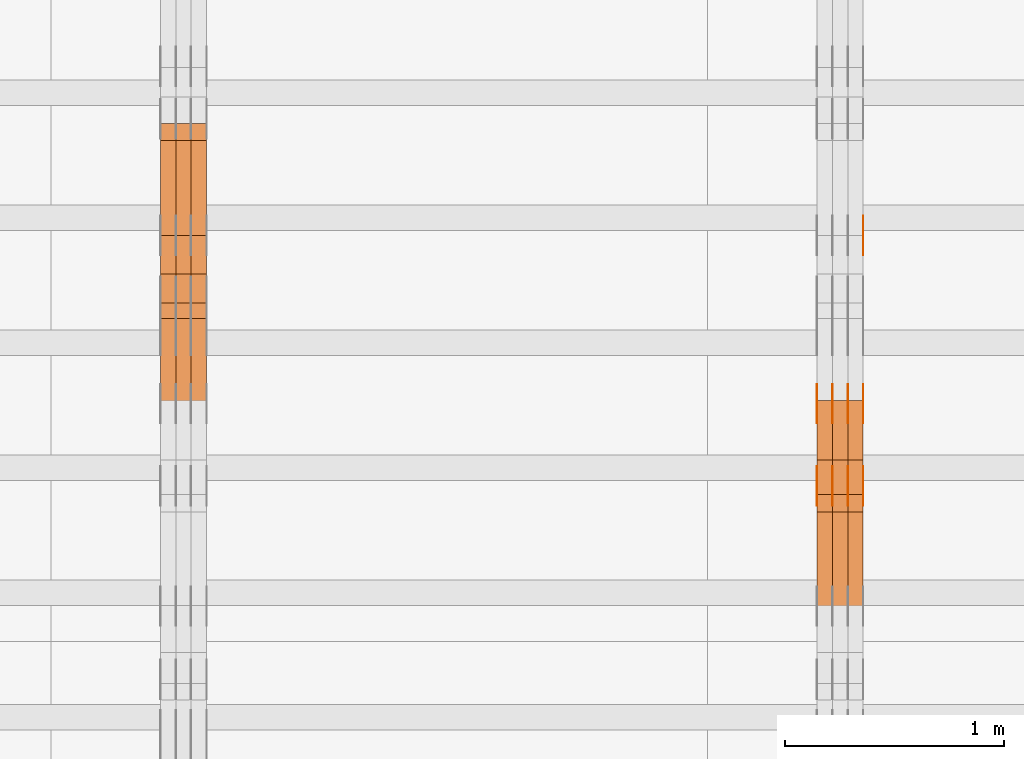
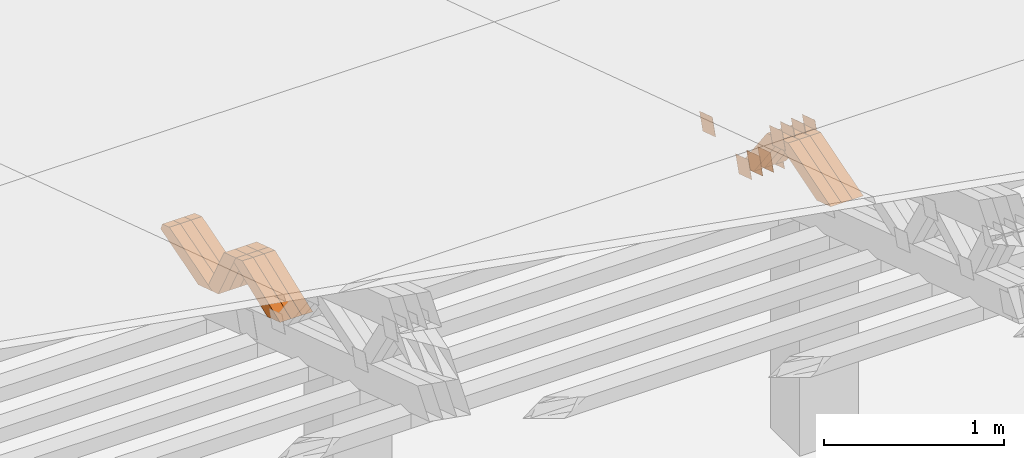
# One storey, part 340 of 385: 28 proxies.
"""IFC2X3 building model written with IfcOpenShell, lengths in millimetres."""

from ifc_helpers import new_model, entity, si_unit, converted_unit, derived_unit, direction, frame, origin, place, context, subcontext, project, spatial, polyline, outline, extrude, source, transform, mapped, material, type_object, type_shapes, element, save


model = new_model("IFC2X3")

# Units and contexts
model_context = context("Model", 3, precision=0.01, world=origin(), true_north=direction((6.12303176911189e-17, 1.0)))
body_context = subcontext(model_context, "Body", "Model", "MODEL_VIEW")
ifc_project = project(units=[si_unit("LENGTHUNIT", "METRE", prefix="MILLI"), si_unit("AREAUNIT", "SQUARE_METRE"), si_unit("VOLUMEUNIT", "CUBIC_METRE"), converted_unit("PLANEANGLEUNIT", "DEGREE", entity("IfcRatioMeasure", 0.0174532925199433), si_unit("PLANEANGLEUNIT", "RADIAN"), dimensions=[0, 0, 0, 0, 0, 0, 0]), si_unit("MASSUNIT", "GRAM", prefix="KILO"), derived_unit("MASSDENSITYUNIT", [(si_unit("MASSUNIT", "GRAM", prefix="KILO"), 1), (si_unit("LENGTHUNIT", "METRE"), -3)]), si_unit("TIMEUNIT", "SECOND"), si_unit("FREQUENCYUNIT", "HERTZ"), si_unit("THERMODYNAMICTEMPERATUREUNIT", "DEGREE_CELSIUS"), derived_unit("THERMALTRANSMITTANCEUNIT", [(si_unit("MASSUNIT", "GRAM", prefix="KILO"), 1), (si_unit("THERMODYNAMICTEMPERATUREUNIT", "KELVIN"), -1), (si_unit("TIMEUNIT", "SECOND"), -3)]), derived_unit("VOLUMETRICFLOWRATEUNIT", [(si_unit("LENGTHUNIT", "METRE"), 3), (si_unit("TIMEUNIT", "SECOND"), -1)]), si_unit("ELECTRICCURRENTUNIT", "AMPERE"), si_unit("ELECTRICVOLTAGEUNIT", "VOLT"), si_unit("POWERUNIT", "WATT"), si_unit("FORCEUNIT", "NEWTON", prefix="KILO"), si_unit("ILLUMINANCEUNIT", "LUX"), si_unit("LUMINOUSFLUXUNIT", "LUMEN"), si_unit("LUMINOUSINTENSITYUNIT", "CANDELA"), derived_unit("USERDEFINED", [(si_unit("MASSUNIT", "GRAM", prefix="KILO"), -1), (si_unit("LENGTHUNIT", "METRE"), -2), (si_unit("TIMEUNIT", "SECOND"), 3), (si_unit("LUMINOUSFLUXUNIT", "LUMEN"), 1)]), derived_unit("LINEARVELOCITYUNIT", [(si_unit("LENGTHUNIT", "METRE"), 1), (si_unit("TIMEUNIT", "SECOND"), -1)]), si_unit("PRESSUREUNIT", "PASCAL"), derived_unit("USERDEFINED", [(si_unit("LENGTHUNIT", "METRE"), -2), (si_unit("MASSUNIT", "GRAM", prefix="KILO"), 1), (si_unit("TIMEUNIT", "SECOND"), -2)])], contexts=[model_context])

# Site, building, storey
site_placement = place(None, origin())
site = spatial("IfcSite", under=ifc_project, at=site_placement, CompositionType="ELEMENT")
building_placement = place(site_placement, origin())
building = spatial("IfcBuilding", under=site, at=building_placement, CompositionType="ELEMENT")
storey_placement = place(building_placement, origin())
storey = spatial("IfcBuildingStorey", under=building, at=storey_placement, Name="Default", CompositionType="ELEMENT", Elevation=0.0)

# Proxies
ifc_material_1 = material(Name="IfcSurfaceStyle #481860")
building_element_proxy_type_1 = type_object("IfcBuildingElementProxyType", PredefinedType="NOTDEFINED", material=ifc_material_1)
shared_shape_1 = source(origin(), body_context, "Body", "SweptSolid", [
    extrude(outline(polyline([(-74.9998794200123, -59.999984515643), (74.9998565677174, -59.999984515643), (74.9998794200123, 59.999984515643), (-74.9998565677174, 59.999984515643), (-74.9998794200123, -59.999984515643)])), frame((75.0000769557496, 60.0000596852268, 0.0), z_axis=(0.0, 0.0, 1.0), x_axis=(-1.0, 0.0, 0.0)), (0.0, 0.0, 1.0), 1.3),
])
type_shapes(building_element_proxy_type_1, [shared_shape_1])
proxy_1_placement = place(building_placement, frame((39386.3, 22649.3668870864, 1282.62115477841), z_axis=(-1.0, 0.0, 0.0), x_axis=(0.0, -0.951056516295124, 0.309016994375039)))
element("IfcBuildingElementProxy", 1, at=proxy_1_placement, inside=storey, type_object=building_element_proxy_type_1, material=ifc_material_1, context=body_context, shape_type="MappedRepresentation", body=[
    mapped(shared_shape_1, transform((0.0, 0.0, 0.0), scale=1.0)),
])
ifc_material_2 = material(Name="IfcSurfaceStyle #478782")
building_element_proxy_type_2 = type_object("IfcBuildingElementProxyType", PredefinedType="NOTDEFINED", material=ifc_material_2)
shared_shape_2 = source(origin(), body_context, "Body", "SweptSolid", [
    extrude(outline(polyline([(-75.0001116115454, -60.0000599592451), (75.0000887592496, -60.0000599592451), (75.0001116115454, 60.0000599592451), (-75.0000887592496, 60.0000599592451), (-75.0001116115454, -60.0000599592451)])), frame((75.0001116115454, 60.0000599592451, 0.0), z_axis=(0.0, 0.0, 1.0), x_axis=(-1.0, 0.0, 0.0)), (0.0, 0.0, 1.0), 1.3),
])
type_shapes(building_element_proxy_type_2, [shared_shape_2])
proxy_2_placement = place(building_placement, frame((39386.3, 21881.0815195707, 1532.2522473242), z_axis=(-1.0, 0.0, 0.0), x_axis=(0.0, -0.951056516295124, 0.309016994375039)))
element("IfcBuildingElementProxy", 2, at=proxy_2_placement, inside=storey, type_object=building_element_proxy_type_2, material=ifc_material_2, context=body_context, shape_type="MappedRepresentation", body=[
    mapped(shared_shape_2, transform((0.0, 0.0, 0.0), scale=1.0)),
])
ifc_material_3 = material(Name="IfcSurfaceStyle #478725")
building_element_proxy_type_3 = type_object("IfcBuildingElementProxyType", PredefinedType="NOTDEFINED", material=ifc_material_3)
shared_shape_3 = source(origin(), body_context, "Body", "SweptSolid", [
    extrude(outline(polyline([(-75.0001116115454, -60.0000599592451), (75.0000887592496, -60.0000599592451), (75.0001116115454, 60.0000599592451), (-75.0000887592496, 60.0000599592451), (-75.0001116115454, -60.0000599592451)])), frame((75.0001116115454, 60.0000599592451, 0.0), z_axis=(0.0, 0.0, 1.0), x_axis=(-1.0, 0.0, 0.0)), (0.0, 0.0, 1.0), 1.3),
])
type_shapes(building_element_proxy_type_3, [shared_shape_3])
proxy_3_placement = place(building_placement, frame((39315.0, 21881.0815195707, 1532.2522473242), z_axis=(-1.0, 0.0, 0.0), x_axis=(0.0, -0.951056516295124, 0.309016994375039)))
element("IfcBuildingElementProxy", 3, at=proxy_3_placement, inside=storey, type_object=building_element_proxy_type_3, material=ifc_material_3, context=body_context, shape_type="MappedRepresentation", body=[
    mapped(shared_shape_3, transform((0.0, 0.0, 0.0), scale=1.0)),
])
ifc_material_4 = material(Name="IfcSurfaceStyle #478668")
building_element_proxy_type_4 = type_object("IfcBuildingElementProxyType", PredefinedType="NOTDEFINED", material=ifc_material_4)
shared_shape_4 = source(origin(), body_context, "Body", "SweptSolid", [
    extrude(outline(polyline([(-75.0001116115454, -60.0000599592451), (75.0000887592496, -60.0000599592451), (75.0001116115454, 60.0000599592451), (-75.0000887592496, 60.0000599592451), (-75.0001116115454, -60.0000599592451)])), frame((75.0001116115454, 60.0000599592451, 0.0), z_axis=(0.0, 0.0, 1.0), x_axis=(-1.0, 0.0, 0.0)), (0.0, 0.0, 1.0), 1.3),
])
type_shapes(building_element_proxy_type_4, [shared_shape_4])
proxy_4_placement = place(building_placement, frame((39316.3, 21881.0815195707, 1532.2522473242), z_axis=(-1.0, 0.0, 0.0), x_axis=(0.0, -0.951056516295124, 0.309016994375039)))
element("IfcBuildingElementProxy", 4, at=proxy_4_placement, inside=storey, type_object=building_element_proxy_type_4, material=ifc_material_4, context=body_context, shape_type="MappedRepresentation", body=[
    mapped(shared_shape_4, transform((0.0, 0.0, 0.0), scale=1.0)),
])
ifc_material_5 = material(Name="IfcSurfaceStyle #478611")
building_element_proxy_type_5 = type_object("IfcBuildingElementProxyType", PredefinedType="NOTDEFINED", material=ifc_material_5)
shared_shape_5 = source(origin(), body_context, "Body", "SweptSolid", [
    extrude(outline(polyline([(-75.0001116115454, -60.0000599592451), (75.0000887592496, -60.0000599592451), (75.0001116115454, 60.0000599592451), (-75.0000887592496, 60.0000599592451), (-75.0001116115454, -60.0000599592451)])), frame((75.0001116115454, 60.0000599592451, 0.0), z_axis=(0.0, 0.0, 1.0), x_axis=(-1.0, 0.0, 0.0)), (0.0, 0.0, 1.0), 1.29999999999999),
])
type_shapes(building_element_proxy_type_5, [shared_shape_5])
proxy_5_placement = place(building_placement, frame((39245.0, 21881.0815195707, 1532.2522473242), z_axis=(-1.0, 0.0, 0.0), x_axis=(0.0, -0.951056516295124, 0.309016994375039)))
element("IfcBuildingElementProxy", 5, at=proxy_5_placement, inside=storey, type_object=building_element_proxy_type_5, material=ifc_material_5, context=body_context, shape_type="MappedRepresentation", body=[
    mapped(shared_shape_5, transform((0.0, 0.0, 0.0), scale=1.0)),
])
ifc_material_6 = material(Name="IfcSurfaceStyle #478554")
building_element_proxy_type_6 = type_object("IfcBuildingElementProxyType", PredefinedType="NOTDEFINED", material=ifc_material_6)
shared_shape_6 = source(origin(), body_context, "Body", "SweptSolid", [
    extrude(outline(polyline([(-75.0001116115454, -60.0000599592451), (75.0000887592496, -60.0000599592451), (75.0001116115454, 60.0000599592451), (-75.0000887592496, 60.0000599592451), (-75.0001116115454, -60.0000599592451)])), frame((75.0001116115454, 60.0000599592451, 0.0), z_axis=(0.0, 0.0, 1.0), x_axis=(-1.0, 0.0, 0.0)), (0.0, 0.0, 1.0), 1.29999999999999),
])
type_shapes(building_element_proxy_type_6, [shared_shape_6])
proxy_6_placement = place(building_placement, frame((39246.3, 21881.0815195707, 1532.2522473242), z_axis=(-1.0, 0.0, 0.0), x_axis=(0.0, -0.951056516295124, 0.309016994375039)))
element("IfcBuildingElementProxy", 6, at=proxy_6_placement, inside=storey, type_object=building_element_proxy_type_6, material=ifc_material_6, context=body_context, shape_type="MappedRepresentation", body=[
    mapped(shared_shape_6, transform((0.0, 0.0, 0.0), scale=1.0)),
])
ifc_material_7 = material(Name="IfcSurfaceStyle #478497")
building_element_proxy_type_7 = type_object("IfcBuildingElementProxyType", PredefinedType="NOTDEFINED", material=ifc_material_7)
shared_shape_7 = source(origin(), body_context, "Body", "SweptSolid", [
    extrude(outline(polyline([(-75.0001116115454, -60.0000599592451), (75.0000887592496, -60.0000599592451), (75.0001116115454, 60.0000599592451), (-75.0000887592496, 60.0000599592451), (-75.0001116115454, -60.0000599592451)])), frame((75.0001116115454, 60.0000599592451, 0.0), z_axis=(0.0, 0.0, 1.0), x_axis=(-1.0, 0.0, 0.0)), (0.0, 0.0, 1.0), 1.29999999999999),
])
type_shapes(building_element_proxy_type_7, [shared_shape_7])
proxy_7_placement = place(building_placement, frame((39175.0, 21881.0815195707, 1532.2522473242), z_axis=(-1.0, 0.0, 0.0), x_axis=(0.0, -0.951056516295124, 0.309016994375039)))
element("IfcBuildingElementProxy", 7, at=proxy_7_placement, inside=storey, type_object=building_element_proxy_type_7, material=ifc_material_7, context=body_context, shape_type="MappedRepresentation", body=[
    mapped(shared_shape_7, transform((0.0, 0.0, 0.0), scale=1.0)),
])
ifc_material_8 = material(Name="IfcSurfaceStyle #473310")
building_element_proxy_type_8 = type_object("IfcBuildingElementProxyType", PredefinedType="NOTDEFINED", material=ifc_material_8)
shared_shape_8 = source(origin(), body_context, "Body", "SweptSolid", [
    extrude(outline(polyline([(-74.9998794200064, -59.9999845156358), (74.9998565677224, -59.9999845156358), (74.9998794200064, 59.9999845156358), (-74.9998565677224, 59.9999845156358), (-74.9998794200064, -59.9999845156358)])), frame((74.9999765995044, 60.0000596852337, 0.0), z_axis=(0.0, 0.0, 1.0), x_axis=(-1.0, 0.0, 0.0)), (0.0, 0.0, 1.0), 1.3),
])
type_shapes(building_element_proxy_type_8, [shared_shape_8])
proxy_8_placement = place(building_placement, frame((39386.3, 21505.9776314857, 1954.5332951652), z_axis=(-1.0, 0.0, 0.0), x_axis=(0.0, -0.951056516295154, 0.309016994374948)))
element("IfcBuildingElementProxy", 8, at=proxy_8_placement, inside=storey, type_object=building_element_proxy_type_8, material=ifc_material_8, context=body_context, shape_type="MappedRepresentation", body=[
    mapped(shared_shape_8, transform((0.0, 0.0, 0.0), scale=1.0)),
])
ifc_material_9 = material(Name="IfcSurfaceStyle #473253")
building_element_proxy_type_9 = type_object("IfcBuildingElementProxyType", PredefinedType="NOTDEFINED", material=ifc_material_9)
shared_shape_9 = source(origin(), body_context, "Body", "SweptSolid", [
    extrude(outline(polyline([(-74.9998794200064, -59.9999845156358), (74.9998565677224, -59.9999845156358), (74.9998794200064, 59.9999845156358), (-74.9998565677224, 59.9999845156358), (-74.9998794200064, -59.9999845156358)])), frame((74.9999765995044, 60.0000596852337, 0.0), z_axis=(0.0, 0.0, 1.0), x_axis=(-1.0, 0.0, 0.0)), (0.0, 0.0, 1.0), 1.3),
])
type_shapes(building_element_proxy_type_9, [shared_shape_9])
proxy_9_placement = place(building_placement, frame((39315.0, 21505.9776314857, 1954.5332951652), z_axis=(-1.0, 0.0, 0.0), x_axis=(0.0, -0.951056516295154, 0.309016994374948)))
element("IfcBuildingElementProxy", 9, at=proxy_9_placement, inside=storey, type_object=building_element_proxy_type_9, material=ifc_material_9, context=body_context, shape_type="MappedRepresentation", body=[
    mapped(shared_shape_9, transform((0.0, 0.0, 0.0), scale=1.0)),
])
ifc_material_10 = material(Name="IfcSurfaceStyle #473196")
building_element_proxy_type_10 = type_object("IfcBuildingElementProxyType", PredefinedType="NOTDEFINED", material=ifc_material_10)
shared_shape_10 = source(origin(), body_context, "Body", "SweptSolid", [
    extrude(outline(polyline([(-74.9998794200064, -59.9999845156358), (74.9998565677224, -59.9999845156358), (74.9998794200064, 59.9999845156358), (-74.9998565677224, 59.9999845156358), (-74.9998794200064, -59.9999845156358)])), frame((74.9999765995044, 60.0000596852337, 0.0), z_axis=(0.0, 0.0, 1.0), x_axis=(-1.0, 0.0, 0.0)), (0.0, 0.0, 1.0), 1.3),
])
type_shapes(building_element_proxy_type_10, [shared_shape_10])
proxy_10_placement = place(building_placement, frame((39316.3, 21505.9776314857, 1954.5332951652), z_axis=(-1.0, 0.0, 0.0), x_axis=(0.0, -0.951056516295154, 0.309016994374948)))
element("IfcBuildingElementProxy", 10, at=proxy_10_placement, inside=storey, type_object=building_element_proxy_type_10, material=ifc_material_10, context=body_context, shape_type="MappedRepresentation", body=[
    mapped(shared_shape_10, transform((0.0, 0.0, 0.0), scale=1.0)),
])
ifc_material_11 = material(Name="IfcSurfaceStyle #473139")
building_element_proxy_type_11 = type_object("IfcBuildingElementProxyType", PredefinedType="NOTDEFINED", material=ifc_material_11)
shared_shape_11 = source(origin(), body_context, "Body", "SweptSolid", [
    extrude(outline(polyline([(-74.9998794200064, -59.9999845156358), (74.9998565677224, -59.9999845156358), (74.9998794200064, 59.9999845156358), (-74.9998565677224, 59.9999845156358), (-74.9998794200064, -59.9999845156358)])), frame((74.9999765995044, 60.0000596852337, 0.0), z_axis=(0.0, 0.0, 1.0), x_axis=(-1.0, 0.0, 0.0)), (0.0, 0.0, 1.0), 1.29999999999999),
])
type_shapes(building_element_proxy_type_11, [shared_shape_11])
proxy_11_placement = place(building_placement, frame((39245.0, 21505.9776314857, 1954.5332951652), z_axis=(-1.0, 0.0, 0.0), x_axis=(0.0, -0.951056516295154, 0.309016994374948)))
element("IfcBuildingElementProxy", 11, at=proxy_11_placement, inside=storey, type_object=building_element_proxy_type_11, material=ifc_material_11, context=body_context, shape_type="MappedRepresentation", body=[
    mapped(shared_shape_11, transform((0.0, 0.0, 0.0), scale=1.0)),
])
ifc_material_12 = material(Name="IfcSurfaceStyle #473082")
building_element_proxy_type_12 = type_object("IfcBuildingElementProxyType", PredefinedType="NOTDEFINED", material=ifc_material_12)
shared_shape_12 = source(origin(), body_context, "Body", "SweptSolid", [
    extrude(outline(polyline([(-74.9998794200064, -59.9999845156358), (74.9998565677224, -59.9999845156358), (74.9998794200064, 59.9999845156358), (-74.9998565677224, 59.9999845156358), (-74.9998794200064, -59.9999845156358)])), frame((74.9999765995044, 60.0000596852337, 0.0), z_axis=(0.0, 0.0, 1.0), x_axis=(-1.0, 0.0, 0.0)), (0.0, 0.0, 1.0), 1.29999999999999),
])
type_shapes(building_element_proxy_type_12, [shared_shape_12])
proxy_12_placement = place(building_placement, frame((39246.3, 21505.9776314857, 1954.5332951652), z_axis=(-1.0, 0.0, 0.0), x_axis=(0.0, -0.951056516295154, 0.309016994374948)))
element("IfcBuildingElementProxy", 12, at=proxy_12_placement, inside=storey, type_object=building_element_proxy_type_12, material=ifc_material_12, context=body_context, shape_type="MappedRepresentation", body=[
    mapped(shared_shape_12, transform((0.0, 0.0, 0.0), scale=1.0)),
])
ifc_material_13 = material(Name="IfcSurfaceStyle #473025")
building_element_proxy_type_13 = type_object("IfcBuildingElementProxyType", PredefinedType="NOTDEFINED", material=ifc_material_13)
shared_shape_13 = source(origin(), body_context, "Body", "SweptSolid", [
    extrude(outline(polyline([(-74.9998794200064, -59.9999845156358), (74.9998565677224, -59.9999845156358), (74.9998794200064, 59.9999845156358), (-74.9998565677224, 59.9999845156358), (-74.9998794200064, -59.9999845156358)])), frame((74.9999765995044, 60.0000596852337, 0.0), z_axis=(0.0, 0.0, 1.0), x_axis=(-1.0, 0.0, 0.0)), (0.0, 0.0, 1.0), 1.29999999999999),
])
type_shapes(building_element_proxy_type_13, [shared_shape_13])
proxy_13_placement = place(building_placement, frame((39175.0, 21505.9776314857, 1954.5332951652), z_axis=(-1.0, 0.0, 0.0), x_axis=(0.0, -0.951056516295154, 0.309016994374948)))
element("IfcBuildingElementProxy", 13, at=proxy_13_placement, inside=storey, type_object=building_element_proxy_type_13, material=ifc_material_13, context=body_context, shape_type="MappedRepresentation", body=[
    mapped(shared_shape_13, transform((0.0, 0.0, 0.0), scale=1.0)),
])
ifc_material_14 = material(Name="IfcSurfaceStyle #461070")
building_element_proxy_type_14 = type_object("IfcBuildingElementProxyType", Name="T1-W20 461068", PredefinedType="NOTDEFINED", material=ifc_material_14)
shared_shape_14 = source(origin(), body_context, "Body", "SweptSolid", [
    extrude(outline(polyline([(-355.264945969921, -47.5000317999193), (141.064821099313, -47.5000317999193), (208.541978467889, 8.19311626391928e-05), (225.96877763549, 47.499990834338), (-220.31063123277, 47.4999908343379), (-355.264945969921, -47.5000317999193)])), frame((225.968921063481, 47.5000683592689, 0.0), z_axis=(0.0, 0.0, 1.0), x_axis=(-1.0, 0.0, 0.0)), (0.0, 0.0, 1.0), 70.0),
])
type_shapes(building_element_proxy_type_14, [shared_shape_14])
proxy_14_placement = place(building_placement, frame((39385.0, 21443.7472302196, 2007.54830804072), z_axis=(-1.0, 0.0, 0.0), x_axis=(0.0, -0.95556995517236, -0.29476441571515)))
element("IfcBuildingElementProxy", 14, at=proxy_14_placement, inside=storey, type_object=building_element_proxy_type_14, material=ifc_material_14, Name="T1-W20", context=body_context, shape_type="MappedRepresentation", body=[
    mapped(shared_shape_14, transform((0.0, 0.0, 0.0), scale=1.0)),
])
ifc_material_15 = material(Name="IfcSurfaceStyle #461004")
building_element_proxy_type_15 = type_object("IfcBuildingElementProxyType", Name="T1-W20 461002", PredefinedType="NOTDEFINED", material=ifc_material_15)
shared_shape_15 = source(origin(), body_context, "Body", "SweptSolid", [
    extrude(outline(polyline([(-355.264945969921, -47.5000317999193), (141.064821099313, -47.5000317999193), (208.541978467889, 8.19311626391928e-05), (225.96877763549, 47.499990834338), (-220.31063123277, 47.4999908343379), (-355.264945969921, -47.5000317999193)])), frame((225.968921063481, 47.5000683592689, 0.0), z_axis=(0.0, 0.0, 1.0), x_axis=(-1.0, 0.0, 0.0)), (0.0, 0.0, 1.0), 70.0),
])
type_shapes(building_element_proxy_type_15, [shared_shape_15])
proxy_15_placement = place(building_placement, frame((39315.0, 21443.7472302196, 2007.54830804072), z_axis=(-1.0, 0.0, 0.0), x_axis=(0.0, -0.95556995517236, -0.29476441571515)))
element("IfcBuildingElementProxy", 15, at=proxy_15_placement, inside=storey, type_object=building_element_proxy_type_15, material=ifc_material_15, Name="T1-W20", context=body_context, shape_type="MappedRepresentation", body=[
    mapped(shared_shape_15, transform((0.0, 0.0, 0.0), scale=1.0)),
])
ifc_material_16 = material(Name="IfcSurfaceStyle #460938")
building_element_proxy_type_16 = type_object("IfcBuildingElementProxyType", Name="T1-W20 460936", PredefinedType="NOTDEFINED", material=ifc_material_16)
shared_shape_16 = source(origin(), body_context, "Body", "SweptSolid", [
    extrude(outline(polyline([(-355.264945969921, -47.5000317999193), (141.064821099313, -47.5000317999193), (208.541978467889, 8.19311626391928e-05), (225.96877763549, 47.499990834338), (-220.31063123277, 47.4999908343379), (-355.264945969921, -47.5000317999193)])), frame((225.968921063481, 47.5000683592689, 0.0), z_axis=(0.0, 0.0, 1.0), x_axis=(-1.0, 0.0, 0.0)), (0.0, 0.0, 1.0), 70.0),
])
type_shapes(building_element_proxy_type_16, [shared_shape_16])
proxy_16_placement = place(building_placement, frame((39245.0, 21443.7472302196, 2007.54830804072), z_axis=(-1.0, 0.0, 0.0), x_axis=(0.0, -0.95556995517236, -0.29476441571515)))
element("IfcBuildingElementProxy", 16, at=proxy_16_placement, inside=storey, type_object=building_element_proxy_type_16, material=ifc_material_16, Name="T1-W20", context=body_context, shape_type="MappedRepresentation", body=[
    mapped(shared_shape_16, transform((0.0, 0.0, 0.0), scale=1.0)),
])
ifc_material_17 = material(Name="IfcSurfaceStyle #460674")
building_element_proxy_type_17 = type_object("IfcBuildingElementProxyType", Name="T1-W18 460672", PredefinedType="NOTDEFINED", material=ifc_material_17)
shared_shape_17 = source(origin(), body_context, "Body", "SweptSolid", [
    extrude(outline(polyline([(-221.504996322134, -47.4999929258616), (225.406467948779, -47.4999929258616), (211.663832468686, -0.000107703153482008), (143.08905281687, 47.5000467774384), (-358.6543569122, 47.5000467774384), (-221.504996322134, -47.4999929258616)])), frame((225.406576158364, 47.5000467774384, 0.0), z_axis=(0.0, 0.0, 1.0), x_axis=(-1.0, 0.0, 0.0)), (0.0, 0.0, 1.0), 70.0),
])
type_shapes(building_element_proxy_type_17, [shared_shape_17])
proxy_17_placement = place(building_placement, frame((39385.0, 21766.9513837803, 1583.13813361817), z_axis=(-1.0, 0.0, 0.0), x_axis=(0.0, -0.605858491298265, 0.795572428206126)))
element("IfcBuildingElementProxy", 17, at=proxy_17_placement, inside=storey, type_object=building_element_proxy_type_17, material=ifc_material_17, Name="T1-W18", context=body_context, shape_type="MappedRepresentation", body=[
    mapped(shared_shape_17, transform((0.0, 0.0, 0.0), scale=1.0)),
])
ifc_material_18 = material(Name="IfcSurfaceStyle #460608")
building_element_proxy_type_18 = type_object("IfcBuildingElementProxyType", Name="T1-W18 460606", PredefinedType="NOTDEFINED", material=ifc_material_18)
shared_shape_18 = source(origin(), body_context, "Body", "SweptSolid", [
    extrude(outline(polyline([(-221.504996322134, -47.4999929258616), (225.406467948779, -47.4999929258616), (211.663832468686, -0.000107703153482008), (143.08905281687, 47.5000467774384), (-358.6543569122, 47.5000467774384), (-221.504996322134, -47.4999929258616)])), frame((225.406576158364, 47.5000467774384, 0.0), z_axis=(0.0, 0.0, 1.0), x_axis=(-1.0, 0.0, 0.0)), (0.0, 0.0, 1.0), 70.0),
])
type_shapes(building_element_proxy_type_18, [shared_shape_18])
proxy_18_placement = place(building_placement, frame((39315.0, 21766.9513837803, 1583.13813361817), z_axis=(-1.0, 0.0, 0.0), x_axis=(0.0, -0.605858491298265, 0.795572428206126)))
element("IfcBuildingElementProxy", 18, at=proxy_18_placement, inside=storey, type_object=building_element_proxy_type_18, material=ifc_material_18, Name="T1-W18", context=body_context, shape_type="MappedRepresentation", body=[
    mapped(shared_shape_18, transform((0.0, 0.0, 0.0), scale=1.0)),
])
ifc_material_19 = material(Name="IfcSurfaceStyle #460542")
building_element_proxy_type_19 = type_object("IfcBuildingElementProxyType", Name="T1-W18 460540", PredefinedType="NOTDEFINED", material=ifc_material_19)
shared_shape_19 = source(origin(), body_context, "Body", "SweptSolid", [
    extrude(outline(polyline([(-221.504996322134, -47.4999929258616), (225.406467948779, -47.4999929258616), (211.663832468686, -0.000107703153482008), (143.08905281687, 47.5000467774384), (-358.6543569122, 47.5000467774384), (-221.504996322134, -47.4999929258616)])), frame((225.406576158364, 47.5000467774384, 0.0), z_axis=(0.0, 0.0, 1.0), x_axis=(-1.0, 0.0, 0.0)), (0.0, 0.0, 1.0), 70.0),
])
type_shapes(building_element_proxy_type_19, [shared_shape_19])
proxy_19_placement = place(building_placement, frame((39245.0, 21766.9513837803, 1583.13813361817), z_axis=(-1.0, 0.0, 0.0), x_axis=(0.0, -0.605858491298265, 0.795572428206126)))
element("IfcBuildingElementProxy", 19, at=proxy_19_placement, inside=storey, type_object=building_element_proxy_type_19, material=ifc_material_19, Name="T1-W18", context=body_context, shape_type="MappedRepresentation", body=[
    mapped(shared_shape_19, transform((0.0, 0.0, 0.0), scale=1.0)),
])
ifc_material_20 = material(Name="IfcSurfaceStyle #425846")
building_element_proxy_type_20 = type_object("IfcBuildingElementProxyType", Name="T1-W30 425844", PredefinedType="NOTDEFINED", material=ifc_material_20)
shared_shape_20 = source(origin(), body_context, "Body", "SweptSolid", [
    extrude(outline(polyline([(-319.322304176575, -47.5000259045904), (133.154090927094, -47.5000259045904), (191.489196707701, 6.99403755251016e-06), (197.330697834052, 47.5000224075717), (-202.651681292271, 47.5000224075717), (-319.322304176575, -47.5000259045904)])), frame((197.330834478517, 47.5000608592405, 0.0), z_axis=(0.0, 0.0, 1.0), x_axis=(-1.0, 0.0, 0.0)), (0.0, 0.0, 1.0), 70.0),
])
type_shapes(building_element_proxy_type_20, [shared_shape_20])
proxy_20_placement = place(building_placement, frame((36385.0, 22312.5352975627, 1720.70362673362), z_axis=(-1.0, 0.0, 0.0), x_axis=(0.0, -0.932610696879359, -0.360884036868072)))
element("IfcBuildingElementProxy", 20, at=proxy_20_placement, inside=storey, type_object=building_element_proxy_type_20, material=ifc_material_20, Name="T1-W30", context=body_context, shape_type="MappedRepresentation", body=[
    mapped(shared_shape_20, transform((0.0, 0.0, 0.0), scale=1.0)),
])
ifc_material_21 = material(Name="IfcSurfaceStyle #425780")
building_element_proxy_type_21 = type_object("IfcBuildingElementProxyType", Name="T1-W30 425778", PredefinedType="NOTDEFINED", material=ifc_material_21)
shared_shape_21 = source(origin(), body_context, "Body", "SweptSolid", [
    extrude(outline(polyline([(-319.322304176575, -47.5000259045904), (133.154090927094, -47.5000259045904), (191.489196707701, 6.99403755251016e-06), (197.330697834052, 47.5000224075717), (-202.651681292271, 47.5000224075717), (-319.322304176575, -47.5000259045904)])), frame((197.330834478517, 47.5000608592405, 0.0), z_axis=(0.0, 0.0, 1.0), x_axis=(-1.0, 0.0, 0.0)), (0.0, 0.0, 1.0), 70.0),
])
type_shapes(building_element_proxy_type_21, [shared_shape_21])
proxy_21_placement = place(building_placement, frame((36315.0, 22312.5352975627, 1720.70362673362), z_axis=(-1.0, 0.0, 0.0), x_axis=(0.0, -0.932610696879359, -0.360884036868072)))
element("IfcBuildingElementProxy", 21, at=proxy_21_placement, inside=storey, type_object=building_element_proxy_type_21, material=ifc_material_21, Name="T1-W30", context=body_context, shape_type="MappedRepresentation", body=[
    mapped(shared_shape_21, transform((0.0, 0.0, 0.0), scale=1.0)),
])
ifc_material_22 = material(Name="IfcSurfaceStyle #425714")
building_element_proxy_type_22 = type_object("IfcBuildingElementProxyType", Name="T1-W30 425712", PredefinedType="NOTDEFINED", material=ifc_material_22)
shared_shape_22 = source(origin(), body_context, "Body", "SweptSolid", [
    extrude(outline(polyline([(-319.322304176575, -47.5000259045904), (133.154090927094, -47.5000259045904), (191.489196707701, 6.99403755251016e-06), (197.330697834052, 47.5000224075717), (-202.651681292271, 47.5000224075717), (-319.322304176575, -47.5000259045904)])), frame((197.330834478517, 47.5000608592405, 0.0), z_axis=(0.0, 0.0, 1.0), x_axis=(-1.0, 0.0, 0.0)), (0.0, 0.0, 1.0), 70.0),
])
type_shapes(building_element_proxy_type_22, [shared_shape_22])
proxy_22_placement = place(building_placement, frame((36245.0, 22312.5352975627, 1720.70362673362), z_axis=(-1.0, 0.0, 0.0), x_axis=(0.0, -0.932610696879359, -0.360884036868072)))
element("IfcBuildingElementProxy", 22, at=proxy_22_placement, inside=storey, type_object=building_element_proxy_type_22, material=ifc_material_22, Name="T1-W30", context=body_context, shape_type="MappedRepresentation", body=[
    mapped(shared_shape_22, transform((0.0, 0.0, 0.0), scale=1.0)),
])
ifc_material_23 = material(Name="IfcSurfaceStyle #425450")
building_element_proxy_type_23 = type_object("IfcBuildingElementProxyType", Name="T1-W41 425448", PredefinedType="NOTDEFINED", material=ifc_material_23)
shared_shape_23 = source(origin(), body_context, "Body", "SweptSolid", [
    extrude(outline(polyline([(-190.064783497519, -47.5001011048749), (182.590736871656, -47.5001011048749), (172.978793750747, 0.000111395300689243), (123.505951450908, 47.5000454072246), (-289.010698575792, 47.5000454072246), (-190.064783497519, -47.5001011048749)])), frame((182.590736871656, 47.5001973817447, 0.0), z_axis=(0.0, 0.0, 1.0), x_axis=(-1.0, 0.0, 0.0)), (0.0, 0.0, 1.0), 70.0),
])
type_shapes(building_element_proxy_type_23, [shared_shape_23])
proxy_23_placement = place(building_placement, frame((36385.0, 22512.5506969063, 1347.13648051689), z_axis=(-1.0, 0.0, 0.0), x_axis=(0.0, -0.472020158706979, 0.881587755004706)))
element("IfcBuildingElementProxy", 23, at=proxy_23_placement, inside=storey, type_object=building_element_proxy_type_23, material=ifc_material_23, Name="T1-W41", context=body_context, shape_type="MappedRepresentation", body=[
    mapped(shared_shape_23, transform((0.0, 0.0, 0.0), scale=1.0)),
])
ifc_material_24 = material(Name="IfcSurfaceStyle #425384")
building_element_proxy_type_24 = type_object("IfcBuildingElementProxyType", Name="T1-W41 425382", PredefinedType="NOTDEFINED", material=ifc_material_24)
shared_shape_24 = source(origin(), body_context, "Body", "SweptSolid", [
    extrude(outline(polyline([(-190.064783497519, -47.5001011048749), (182.590736871656, -47.5001011048749), (172.978793750747, 0.000111395300689243), (123.505951450908, 47.5000454072246), (-289.010698575792, 47.5000454072246), (-190.064783497519, -47.5001011048749)])), frame((182.590736871656, 47.5001973817447, 0.0), z_axis=(0.0, 0.0, 1.0), x_axis=(-1.0, 0.0, 0.0)), (0.0, 0.0, 1.0), 70.0),
])
type_shapes(building_element_proxy_type_24, [shared_shape_24])
proxy_24_placement = place(building_placement, frame((36315.0, 22512.5506969063, 1347.13648051689), z_axis=(-1.0, 0.0, 0.0), x_axis=(0.0, -0.472020158706979, 0.881587755004706)))
element("IfcBuildingElementProxy", 24, at=proxy_24_placement, inside=storey, type_object=building_element_proxy_type_24, material=ifc_material_24, Name="T1-W41", context=body_context, shape_type="MappedRepresentation", body=[
    mapped(shared_shape_24, transform((0.0, 0.0, 0.0), scale=1.0)),
])
ifc_material_25 = material(Name="IfcSurfaceStyle #425318")
building_element_proxy_type_25 = type_object("IfcBuildingElementProxyType", Name="T1-W41 425316", PredefinedType="NOTDEFINED", material=ifc_material_25)
shared_shape_25 = source(origin(), body_context, "Body", "SweptSolid", [
    extrude(outline(polyline([(-190.064783497519, -47.5001011048749), (182.590736871656, -47.5001011048749), (172.978793750747, 0.000111395300689243), (123.505951450908, 47.5000454072246), (-289.010698575792, 47.5000454072246), (-190.064783497519, -47.5001011048749)])), frame((182.590736871656, 47.5001973817447, 0.0), z_axis=(0.0, 0.0, 1.0), x_axis=(-1.0, 0.0, 0.0)), (0.0, 0.0, 1.0), 70.0),
])
type_shapes(building_element_proxy_type_25, [shared_shape_25])
proxy_25_placement = place(building_placement, frame((36245.0, 22512.5506969063, 1347.13648051689), z_axis=(-1.0, 0.0, 0.0), x_axis=(0.0, -0.472020158706979, 0.881587755004706)))
element("IfcBuildingElementProxy", 25, at=proxy_25_placement, inside=storey, type_object=building_element_proxy_type_25, material=ifc_material_25, Name="T1-W41", context=body_context, shape_type="MappedRepresentation", body=[
    mapped(shared_shape_25, transform((0.0, 0.0, 0.0), scale=1.0)),
])
ifc_material_26 = material(Name="IfcSurfaceStyle #425054")
building_element_proxy_type_26 = type_object("IfcBuildingElementProxyType", Name="T1-W23 425052", PredefinedType="NOTDEFINED", material=ifc_material_26)
shared_shape_26 = source(origin(), body_context, "Body", "SweptSolid", [
    extrude(outline(polyline([(-356.808656505462, -47.5000180192671), (144.726334557508, -47.5000180192671), (213.258834104997, -2.90494310381195e-05), (218.567145253444, 47.5000325439826), (-219.743657410487, 47.5000325439827), (-356.808656505462, -47.5000180192671)])), frame((218.567145253444, 47.5000325439826, 0.0), z_axis=(0.0, 0.0, 1.0), x_axis=(-1.0, 0.0, 0.0)), (0.0, 0.0, 1.0), 70.0),
])
type_shapes(building_element_proxy_type_26, [shared_shape_26])
proxy_26_placement = place(building_placement, frame((36385.0, 23128.2626953125, 1452.63940429688), z_axis=(-1.0, 0.0, 0.0), x_axis=(0.0, -0.957692700226705, -0.287792793399143)))
element("IfcBuildingElementProxy", 26, at=proxy_26_placement, inside=storey, type_object=building_element_proxy_type_26, material=ifc_material_26, Name="T1-W23", context=body_context, shape_type="MappedRepresentation", body=[
    mapped(shared_shape_26, transform((0.0, 0.0, 0.0), scale=1.0)),
])
ifc_material_27 = material(Name="IfcSurfaceStyle #424988")
building_element_proxy_type_27 = type_object("IfcBuildingElementProxyType", Name="T1-W23 424986", PredefinedType="NOTDEFINED", material=ifc_material_27)
shared_shape_27 = source(origin(), body_context, "Body", "SweptSolid", [
    extrude(outline(polyline([(-356.808656505462, -47.5000180192671), (144.726334557508, -47.5000180192671), (213.258834104997, -2.90494310381195e-05), (218.567145253444, 47.5000325439826), (-219.743657410487, 47.5000325439827), (-356.808656505462, -47.5000180192671)])), frame((218.567145253444, 47.5000325439826, 0.0), z_axis=(0.0, 0.0, 1.0), x_axis=(-1.0, 0.0, 0.0)), (0.0, 0.0, 1.0), 70.0),
])
type_shapes(building_element_proxy_type_27, [shared_shape_27])
proxy_27_placement = place(building_placement, frame((36315.0, 23128.2626953125, 1452.63940429688), z_axis=(-1.0, 0.0, 0.0), x_axis=(0.0, -0.957692700226705, -0.287792793399143)))
element("IfcBuildingElementProxy", 27, at=proxy_27_placement, inside=storey, type_object=building_element_proxy_type_27, material=ifc_material_27, Name="T1-W23", context=body_context, shape_type="MappedRepresentation", body=[
    mapped(shared_shape_27, transform((0.0, 0.0, 0.0), scale=1.0)),
])
ifc_material_28 = material(Name="IfcSurfaceStyle #424922")
building_element_proxy_type_28 = type_object("IfcBuildingElementProxyType", Name="T1-W23 424920", PredefinedType="NOTDEFINED", material=ifc_material_28)
shared_shape_28 = source(origin(), body_context, "Body", "SweptSolid", [
    extrude(outline(polyline([(-356.808656505462, -47.5000180192671), (144.726334557508, -47.5000180192671), (213.258834104997, -2.90494310381195e-05), (218.567145253444, 47.5000325439826), (-219.743657410487, 47.5000325439827), (-356.808656505462, -47.5000180192671)])), frame((218.567145253444, 47.5000325439826, 0.0), z_axis=(0.0, 0.0, 1.0), x_axis=(-1.0, 0.0, 0.0)), (0.0, 0.0, 1.0), 70.0),
])
type_shapes(building_element_proxy_type_28, [shared_shape_28])
proxy_28_placement = place(building_placement, frame((36245.0, 23128.2626953125, 1452.63940429688), z_axis=(-1.0, 0.0, 0.0), x_axis=(0.0, -0.957692700226705, -0.287792793399143)))
element("IfcBuildingElementProxy", 28, at=proxy_28_placement, inside=storey, type_object=building_element_proxy_type_28, material=ifc_material_28, Name="T1-W23", context=body_context, shape_type="MappedRepresentation", body=[
    mapped(shared_shape_28, transform((0.0, 0.0, 0.0), scale=1.0)),
])

save(model, "model.ifc")
